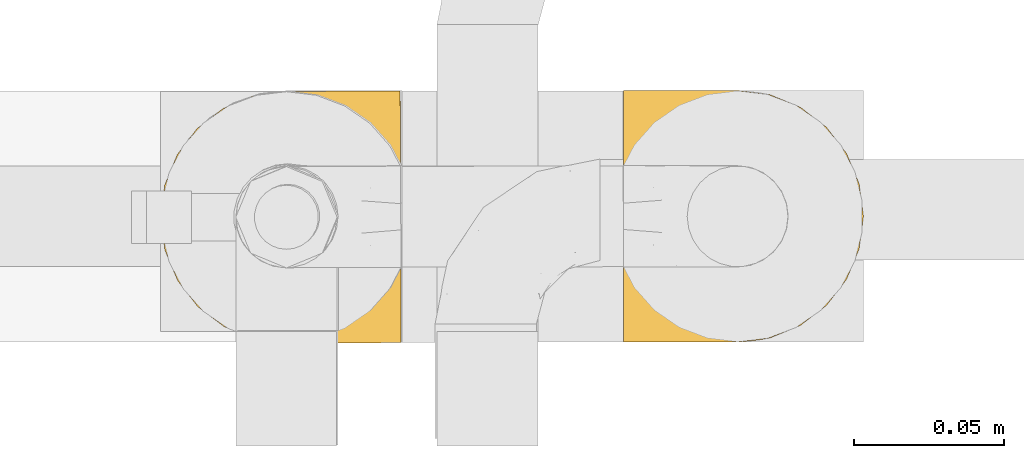
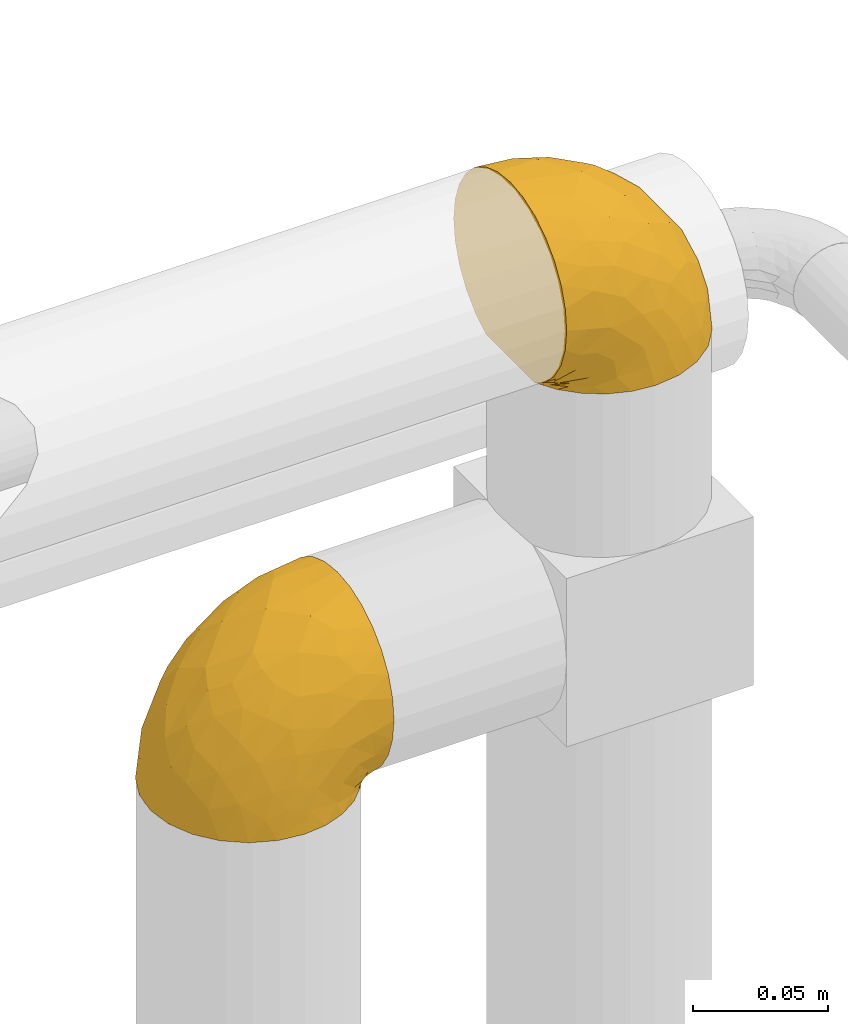
# One storey, part 359 of 827: 2 coverings.
"""IFC2X3 building model written with IfcOpenShell, lengths in millimetres."""

import ifcopenshell
import ifcopenshell.guid

model = None  # the IFC model being written
_history = None  # IfcOwnerHistory: only IFC2X3 demands one
_inside = {}  # id of a spatial element -> (the spatial element, [elements in it])
_under = {}  # id of a project, library or spatial element -> (it, [spatial elements below it])
_declared = {}  # id of a project -> (the project, [libraries it declares])
_typed = {}  # id of a type object -> (the type object, [elements of that type])
_made_of = {}  # id of a material, layer set ... -> (it, [elements and type objects made of it])


def new_model(schema):
    """Start an empty IFC model of exactly this schema.

    Asked for "IFC4X3", IfcOpenShell would pick the latest addendum, in which some entities
    have other attributes; the version numbers below select the first issue.
    IFC2X3 requires an IfcOwnerHistory on every rooted entity: one is made here for all.
    """
    global model, _history
    if schema == "IFC4X3":
        model = ifcopenshell.file(schema_version=(4, 3, 0, 0))
    else:
        model = ifcopenshell.file(schema=schema)
    _inside.clear()
    _under.clear()
    _declared.clear()
    _typed.clear()
    _made_of.clear()
    _history = None
    if model.schema == "IFC2X3":
        org = make("IfcOrganization", Name="unknown")
        user = make(
            "IfcPersonAndOrganization",
            ThePerson=make("IfcPerson", FamilyName="unknown"),
            TheOrganization=org,
        )
        app = make(
            "IfcApplication",
            ApplicationDeveloper=org,
            Version="unknown",
            ApplicationFullName="unknown",
            ApplicationIdentifier="unknown",
        )
        _history = make(
            "IfcOwnerHistory",
            OwningUser=user,
            OwningApplication=app,
            ChangeAction="ADDED",
            CreationDate=0,
        )
    return model


def make(cls, **values):
    """One entity of the class cls with the attributes given. An attribute that is None is left unset."""
    return model.create_entity(
        cls, **{name: value for name, value in values.items() if value is not None}
    )


def entity(cls, *values):
    """Any entity or typed value of the class cls, its attributes in the order of the schema. None: left unset."""
    e = model.create_entity(cls)
    for i, value in enumerate(values):
        if value is not None:
            e[i] = value
    return e


def rooted(cls, **values):
    """An entity with a GlobalId (a new one), such as an element, a storey or a relation."""
    return make(cls, GlobalId=ifcopenshell.guid.new(), OwnerHistory=_history, **values)


def si_unit(unit_type, name, prefix=None):
    """IfcSIUnit, for example si_unit("LENGTHUNIT", "METRE", prefix="MILLI")."""
    return make("IfcSIUnit", UnitType=unit_type, Prefix=prefix, Name=name)


def converted_unit(unit_type, name, factor, base, dimensions=None, offset=None):
    """IfcConversionBasedUnit, such as the inch: factor (a typed value) times the base unit."""
    return make(
        "IfcConversionBasedUnit"
        if offset is None
        else "IfcConversionBasedUnitWithOffset",
        ConversionOffset=offset,
        Dimensions=None
        if dimensions is None
        else entity("IfcDimensionalExponents", *dimensions),
        UnitType=unit_type,
        Name=name,
        ConversionFactor=make(
            "IfcMeasureWithUnit", ValueComponent=factor, UnitComponent=base
        ),
    )


def derived_unit(unit_type, elements):
    """IfcDerivedUnit: a product of units, each with its exponent."""
    return make(
        "IfcDerivedUnit",
        Elements=[
            make("IfcDerivedUnitElement", Unit=unit, Exponent=power)
            for unit, power in elements
        ],
        UnitType=unit_type,
    )


def assignment(units):
    """IfcUnitAssignment: the units of a project."""
    return None if units is None else make("IfcUnitAssignment", Units=units)


def point(xyz):
    """IfcCartesianPoint."""
    return None if xyz is None else make("IfcCartesianPoint", Coordinates=xyz)


def direction(xyz):
    """IfcDirection."""
    return None if xyz is None else make("IfcDirection", DirectionRatios=xyz)


def frame(location, z_axis=None, x_axis=None):
    """IfcAxis2Placement3D, a coordinate frame: its origin and axes. An axis left out is left unset."""
    return make(
        "IfcAxis2Placement3D",
        Location=point(location),
        Axis=direction(z_axis),
        RefDirection=direction(x_axis),
    )


def origin():
    """The frame at (0, 0, 0) with its axes left unset."""
    return frame((0.0, 0.0, 0.0))


def place(relative_to, where):
    """IfcLocalPlacement: puts the frame where relative to a parent placement (None: the world)."""
    return make(
        "IfcLocalPlacement", PlacementRelTo=relative_to, RelativePlacement=where
    )


def context(
    kind, dimensions, precision=None, world=None, true_north=None, identifier=None
):
    """IfcGeometricRepresentationContext, for example the 3D "Model" context."""
    return make(
        "IfcGeometricRepresentationContext",
        ContextIdentifier=identifier,
        ContextType=kind,
        CoordinateSpaceDimension=dimensions,
        Precision=precision,
        WorldCoordinateSystem=world,
        TrueNorth=true_north,
    )


def subcontext(parent, identifier, kind, view, scale=None):
    """IfcGeometricRepresentationSubContext, for example "Body" below "Model"."""
    return make(
        "IfcGeometricRepresentationSubContext",
        ContextIdentifier=identifier,
        ContextType=kind,
        ParentContext=parent,
        TargetScale=scale,
        TargetView=view,
    )


def project(units=None, contexts=None):
    """IfcProject with its units and contexts."""
    return rooted(
        "IfcProject",
        Name="project",
        RepresentationContexts=contexts,
        UnitsInContext=assignment(units),
    )


def spatial(cls, under=None, at=None, **own):
    """A site, building, storey or space (cls), placed at a placement, below another one or the project."""
    s = rooted(cls, ObjectPlacement=at, **own)
    if under is not None:
        _under.setdefault(under.id(), (under, []))[1].append(s)
    return s


def faces_of(points, faces, orient=None, outer=None):
    """IfcFace entities. A face is a list of loops; a loop is a list of indices into points, from 0.

    orient and outer hold one flag for each loop. By default every Orientation is true, the
    first loop of a face is its IfcFaceOuterBound and the others are IfcFaceBound.
    """
    made = []
    for i, loops in enumerate(faces):
        bounds = []
        for j, loop in enumerate(loops):
            is_outer = j == 0 if outer is None else outer[i][j]
            bounds.append(
                make(
                    "IfcFaceOuterBound" if is_outer else "IfcFaceBound",
                    Bound=make("IfcPolyLoop", Polygon=[points[k] for k in loop]),
                    Orientation=True if orient is None else orient[i][j],
                )
            )
        made.append(make("IfcFace", Bounds=bounds))
    return made


def faceted_brep(points, faces, orient=None, outer=None, voids=None):
    """IfcFacetedBrep: a solid bounded by flat faces; with voids (closed shells), ...WithVoids."""
    shared = [point(p) for p in points]
    hull = make("IfcClosedShell", CfsFaces=faces_of(shared, faces, orient, outer))
    if voids is None:
        return make("IfcFacetedBrep", Outer=hull)
    return make(
        "IfcFacetedBrepWithVoids",
        Outer=hull,
        Voids=[
            make(cls, CfsFaces=faces_of(shared, fs, o, b)) for cls, fs, o, b in voids
        ],
    )


def shape(context_of_items, identifier, shape_type, items):
    """IfcShapeRepresentation: the items that make up one representation, for example the "Body"."""
    return make(
        "IfcShapeRepresentation",
        ContextOfItems=context_of_items,
        RepresentationIdentifier=identifier,
        RepresentationType=shape_type,
        Items=items,
    )


def made_of(thing, what):
    """Note that an element or type object is made of a material, layer set ...; save() writes the relation."""
    if what is not None:
        _made_of.setdefault(what.id(), (what, []))[1].append(thing)
    return thing


def element(
    cls,
    number,
    at=None,
    inside=None,
    cuts=None,
    type_object=None,
    material=None,
    context=None,
    identifier="Body",
    shape_type=None,
    held_by="IfcProductDefinitionShape",
    body=None,
    shapes=None,
    **own,
):
    """One element of the class cls, such as IfcWall. Its Tag is "e" and its number.

    at: its placement. inside: the storey or other place that contains it. cuts: it is an
    opening in that element (IfcRelVoidsElement). A single representation is given by context,
    identifier, shape_type and body (its items); several are given by shapes. held_by: the class
    of the entity that holds the representations. save() writes the other relations.
    """
    e = rooted(cls, Tag="e%d" % number, ObjectPlacement=at, **own)
    if body is not None:
        shapes = [shape(context, identifier, shape_type, body)]
    if shapes is not None:
        e.Representation = make(held_by, Representations=shapes)
    if inside is not None:
        _inside.setdefault(inside.id(), (inside, []))[1].append(e)
    if cuts is not None:
        rooted(
            "IfcRelVoidsElement", RelatingBuildingElement=cuts, RelatedOpeningElement=e
        )
    if type_object is not None:
        _typed.setdefault(type_object.id(), (type_object, []))[1].append(e)
    return made_of(e, material)


def aggregate(whole, parts):
    """IfcRelAggregates: a whole, such as a stair, and the parts it consists of."""
    return rooted("IfcRelAggregates", RelatingObject=whole, RelatedObjects=parts)


def save(model, path):
    """Write the relations noted so far, then the file.

    IfcRelAggregates (storeys below a building ...), IfcRelContainedInSpatialStructure (elements
    in a storey), IfcRelDefinesByType, IfcRelAssociatesMaterial and IfcRelDeclares: one each for
    every whole, place, type object, material and project.
    """
    for whole, parts in _under.values():
        aggregate(whole, parts)
    for where, things in _inside.values():
        rooted(
            "IfcRelContainedInSpatialStructure",
            RelatedElements=things,
            RelatingStructure=where,
        )
    for kind, things in _typed.values():
        rooted("IfcRelDefinesByType", RelatedObjects=things, RelatingType=kind)
    for what, things in _made_of.values():
        rooted("IfcRelAssociatesMaterial", RelatedObjects=things, RelatingMaterial=what)
    for by, libraries in _declared.values():
        rooted("IfcRelDeclares", RelatingContext=by, RelatedDefinitions=libraries)
    model.write(path)


model = new_model("IFC2X3")

# Units and contexts
model_context = context("Model", 3, precision=0.01, world=origin(), true_north=direction((6.12303176911189e-17, 1.0)))
body_context = subcontext(model_context, "Body", "Model", "MODEL_VIEW")
ifc_project = project(units=[si_unit("LENGTHUNIT", "METRE", prefix="MILLI"), si_unit("AREAUNIT", "SQUARE_METRE"), si_unit("VOLUMEUNIT", "CUBIC_METRE"), converted_unit("PLANEANGLEUNIT", "DEGREE", entity("IfcRatioMeasure", 0.0174532925199433), si_unit("PLANEANGLEUNIT", "RADIAN"), dimensions=[0, 0, 0, 0, 0, 0, 0]), si_unit("MASSUNIT", "GRAM", prefix="KILO"), derived_unit("MASSDENSITYUNIT", [(si_unit("MASSUNIT", "GRAM", prefix="KILO"), 1), (si_unit("LENGTHUNIT", "METRE"), -3)]), derived_unit("MOMENTOFINERTIAUNIT", [(si_unit("LENGTHUNIT", "METRE"), 4)]), si_unit("TIMEUNIT", "SECOND"), si_unit("FREQUENCYUNIT", "HERTZ"), si_unit("THERMODYNAMICTEMPERATUREUNIT", "DEGREE_CELSIUS"), derived_unit("THERMALTRANSMITTANCEUNIT", [(si_unit("MASSUNIT", "GRAM", prefix="KILO"), 1), (si_unit("THERMODYNAMICTEMPERATUREUNIT", "KELVIN"), -1), (si_unit("TIMEUNIT", "SECOND"), -3)]), derived_unit("VOLUMETRICFLOWRATEUNIT", [(si_unit("LENGTHUNIT", "METRE"), 3), (si_unit("TIMEUNIT", "SECOND"), -1)]), derived_unit("MASSFLOWRATEUNIT", [(si_unit("MASSUNIT", "GRAM", prefix="KILO"), 1), (si_unit("TIMEUNIT", "SECOND"), -1)]), derived_unit("ROTATIONALFREQUENCYUNIT", [(si_unit("TIMEUNIT", "SECOND"), -1)]), si_unit("ELECTRICCURRENTUNIT", "AMPERE"), si_unit("ELECTRICVOLTAGEUNIT", "VOLT"), si_unit("POWERUNIT", "WATT"), si_unit("FORCEUNIT", "NEWTON", prefix="KILO"), si_unit("ILLUMINANCEUNIT", "LUX"), si_unit("LUMINOUSFLUXUNIT", "LUMEN"), si_unit("LUMINOUSINTENSITYUNIT", "CANDELA"), derived_unit("USERDEFINED", [(si_unit("MASSUNIT", "GRAM", prefix="KILO"), -1), (si_unit("LENGTHUNIT", "METRE"), -2), (si_unit("TIMEUNIT", "SECOND"), 3), (si_unit("LUMINOUSFLUXUNIT", "LUMEN"), 1)]), derived_unit("LINEARVELOCITYUNIT", [(si_unit("LENGTHUNIT", "METRE"), 1), (si_unit("TIMEUNIT", "SECOND"), -1)]), si_unit("PRESSUREUNIT", "PASCAL"), derived_unit("USERDEFINED", [(si_unit("LENGTHUNIT", "METRE"), -2), (si_unit("MASSUNIT", "GRAM", prefix="KILO"), 1), (si_unit("TIMEUNIT", "SECOND"), -2)]), derived_unit("LINEARFORCEUNIT", [(si_unit("MASSUNIT", "GRAM", prefix="KILO"), 1), (si_unit("LENGTHUNIT", "METRE"), 1), (si_unit("TIMEUNIT", "SECOND"), -2), (si_unit("LENGTHUNIT", "METRE"), -1)]), derived_unit("PLANARFORCEUNIT", [(si_unit("MASSUNIT", "GRAM", prefix="KILO"), 1), (si_unit("LENGTHUNIT", "METRE"), 1), (si_unit("TIMEUNIT", "SECOND"), -2), (si_unit("LENGTHUNIT", "METRE"), -2)])], contexts=[model_context])

# Site, building, storey
site_placement = place(None, origin())
site = spatial("IfcSite", under=ifc_project, at=site_placement, CompositionType="ELEMENT")
building_placement = place(site_placement, origin())
building = spatial("IfcBuilding", under=site, at=building_placement, CompositionType="ELEMENT")
storey_placement = place(building_placement, frame((0.0, 0.0, 28200.0)))
storey = spatial("IfcBuildingStorey", under=building, at=storey_placement, Name="08", CompositionType="ELEMENT", Elevation=28200.0)

# Coverings
covering_1_placement = place(storey_placement, frame((43109.64, 18027.49, 2810.4)))
element("IfcCovering", 1, at=covering_1_placement, inside=storey, Name=":ADSK_", ObjectType=":ADSK_", PredefinedType="INSULATION", context=body_context, shape_type="Brep", body=[
    faceted_brep([(81.34, 69.68, 72.32), (81.37, 61.75, 77.3), (81.41, 52.91, 80.4), (81.44, 43.6, 81.45), (81.48, 34.28, 80.39), (81.52, 25.43, 77.3), (81.55, 17.5, 72.31), (81.58, 10.87, 65.68), (81.6, 5.89, 57.75), (81.61, 2.8, 48.9), (81.61, 1.75, 39.6), (81.61, 2.81, 30.22), (81.6, 5.94, 21.33), (81.58, 10.99, 13.37), (81.55, 17.69, 6.73), (81.52, 25.69, 1.77), (81.51, 26.6, 1.77), (81.51, 27.52, 1.77), (81.51, 28.33, 1.77), (81.5, 29.65, 1.77), (81.5, 30.97, 1.77), (81.49, 32.29, 1.77), (81.48, 33.61, 1.77), (81.48, 34.93, 1.77), (81.47, 36.25, 1.77), (81.47, 37.57, 1.77), (81.46, 38.89, 1.77), (81.46, 40.21, 1.77), (81.45, 41.53, 1.77), (81.45, 42.85, 1.77), (81.44, 44.17, 1.77), (81.44, 45.49, 1.77), (81.43, 46.81, 1.77), (81.43, 47.73, 1.77), (81.42, 48.65, 1.77), (81.42, 49.57, 1.77), (81.42, 50.49, 1.77), (81.41, 51.4, 1.77), (81.41, 52.32, 1.77), (81.41, 53.24, 1.77), (81.4, 54.16, 1.77), (81.4, 55.08, 1.77), (81.39, 56.0, 1.77), (81.39, 56.92, 1.77), (81.39, 57.84, 1.77), (81.38, 58.75, 1.77), (81.38, 59.67, 1.77), (81.38, 60.59, 1.77), (81.37, 61.51, 1.77), (81.34, 69.52, 6.74), (81.31, 76.22, 13.38), (81.29, 81.26, 21.35), (81.28, 84.39, 30.24), (81.28, 85.45, 39.6), (81.28, 84.4, 48.91), (81.29, 81.3, 57.76), (81.31, 76.31, 65.69), (76.4, 17.66, 1.6), (69.8, 10.93, 1.6), (61.85, 5.86, 1.6), (52.97, 2.69, 1.6), (43.61, 1.6, 1.6), (32.78, 2.98, 1.6), (22.67, 7.12, 1.6), (13.97, 13.73, 1.6), (7.29, 22.37, 1.6), (3.06, 32.45, 1.6), (1.6, 43.28, 1.6), (2.98, 54.11, 1.6), (7.12, 64.22, 1.6), (13.73, 72.92, 1.6), (22.37, 79.6, 1.6), (32.45, 83.82, 1.6), (43.28, 85.29, 1.6), (52.65, 84.27, 1.6), (61.55, 81.18, 1.6), (69.53, 76.17, 1.6), (76.19, 69.5, 1.6), (81.2, 61.51, 1.6), (81.2, 60.59, 1.6), (81.2, 59.27, 1.6), (81.21, 58.15, 1.6), (81.21, 57.03, 1.6), (81.22, 55.91, 1.6), (81.22, 54.79, 1.6), (81.23, 53.67, 1.6), (81.23, 52.55, 1.6), (81.24, 51.43, 1.6), (81.24, 50.31, 1.6), (81.24, 49.2, 1.6), (81.25, 48.08, 1.6), (81.25, 46.96, 1.6), (81.26, 45.84, 1.6), (81.26, 44.72, 1.6), (81.27, 43.6, 1.6), (81.27, 42.28, 1.6), (81.28, 40.96, 1.6), (81.28, 39.64, 1.6), (81.29, 38.32, 1.6), (81.29, 37.0, 1.6), (81.3, 35.68, 1.6), (81.3, 34.36, 1.6), (81.31, 33.03, 1.6), (81.31, 32.12, 1.6), (81.32, 31.2, 1.6), (81.32, 30.28, 1.6), (81.32, 29.36, 1.6), (81.33, 28.44, 1.6), (81.33, 27.52, 1.6), (81.34, 26.6, 1.6), (81.34, 25.69, 1.6), (81.27, 54.23, 1.71), (81.28, 55.31, 1.73), (81.34, 36.34, 1.71), (81.35, 35.28, 1.72), (81.31, 44.16, 1.71), (81.31, 45.23, 1.72), (81.25, 61.51, 1.72), (81.25, 60.13, 1.72), (81.31, 46.33, 1.72), (81.39, 26.89, 1.72), (81.31, 47.51, 1.72), (81.37, 29.82, 1.72), (81.36, 28.87, 1.7), (81.33, 39.93, 1.72), (81.29, 53.11, 1.73), (81.28, 51.99, 1.72), (81.34, 40.95, 1.73), (81.33, 42.03, 1.73), (81.32, 43.09, 1.72), (81.38, 27.92, 1.72), (81.29, 48.55, 1.71), (81.34, 37.37, 1.72), (81.35, 33.7, 1.71), (81.36, 32.64, 1.72), (81.37, 30.84, 1.72), (81.29, 50.84, 1.72), (81.3, 49.76, 1.73), (81.27, 56.47, 1.72), (81.26, 57.59, 1.71), (81.27, 59.03, 1.73), (81.39, 25.69, 1.72), (81.29, 61.51, 1.74), (81.43, 25.69, 1.74), (81.22, 61.51, 1.64), (81.38, 25.69, 1.68), (81.36, 25.69, 1.64), (81.23, 61.51, 1.68), (81.47, 25.69, 1.75), (81.32, 61.51, 1.75), (81.39, 31.74, 1.74), (81.33, 38.86, 1.71), (58.66, 4.03, 8.98), (72.11, 1.71, 37.05), (74.73, 4.1, 24.69), (74.07, 8.21, 15.28), (78.32, 8.23, 16.86), (78.15, 16.57, 6.58), (76.34, 15.87, 5.71), (46.16, 1.61, 11.1), (74.14, 10.92, 10.79), (73.69, 14.11, 4.13), (66.8, 8.18, 6.62), (79.21, 14.14, 9.52), (73.26, 12.95, 6.14), (60.51, 3.25, 17.79), (48.7, 1.62, 20.6), (45.53, 1.6, 8.73), (67.38, 3.37, 23.66), (62.61, 1.67, 34.5), (68.82, 6.38, 15.32), (55.66, 1.64, 27.55), (77.94, 19.2, 3.31), (68.3, 8.18, 9.81), (74.48, 1.72, 37.68), (38.82, 32.09, 67.23), (62.16, 29.69, 76.64), (50.89, 43.47, 75.37), (37.07, 2.42, 14.58), (40.53, 2.49, 23.71), (28.0, 9.67, 34.34), (15.87, 17.86, 29.1), (20.27, 10.15, 18.02), (31.7, 4.73, 22.27), (28.41, 4.72, 10.97), (57.4, 8.06, 56.79), (70.13, 8.11, 60.76), (64.7, 13.93, 67.04), (50.81, 2.45, 36.11), (52.06, 21.21, 68.85), (5.76, 35.58, 24.58), (7.48, 27.28, 21.54), (66.14, 43.54, 78.4), (11.46, 17.84, 14.11), (21.68, 35.62, 53.42), (28.63, 29.41, 58.19), (55.54, 3.46, 44.49), (68.67, 4.04, 51.77), (67.57, 21.27, 73.69), (40.92, 7.91, 45.89), (41.68, 4.25, 35.97), (46.23, 11.77, 56.55), (40.42, 18.3, 60.03), (38.44, 24.92, 63.64), (11.9, 28.66, 34.98), (12.59, 35.7, 40.58), (7.67, 43.3, 32.15), (19.45, 28.28, 47.26), (24.98, 43.37, 58.06), (37.94, 43.42, 66.71), (4.64, 43.29, 16.9), (28.18, 21.15, 52.08), (23.84, 16.4, 41.21), (34.15, 13.81, 49.76), (16.33, 43.34, 45.11), (29.13, 82.05, 15.65), (5.74, 51.26, 24.57), (21.38, 57.36, 50.54), (38.75, 54.76, 67.25), (64.46, 73.12, 67.06), (67.4, 65.8, 73.7), (22.77, 76.56, 26.13), (12.44, 68.8, 19.54), (19.94, 67.92, 38.96), (57.12, 78.93, 56.8), (69.85, 78.98, 60.77), (68.35, 83.05, 51.78), (34.45, 64.41, 59.09), (38.65, 84.48, 19.25), (48.37, 85.32, 20.6), (45.82, 85.3, 11.1), (74.14, 85.42, 37.68), (5.3, 57.68, 15.21), (18.82, 76.55, 12.76), (12.76, 51.06, 40.93), (62.05, 57.34, 76.65), (33.0, 78.1, 39.5), (33.28, 82.31, 25.01), (51.89, 65.74, 68.86), (43.25, 84.61, 26.7), (48.45, 84.38, 34.95), (62.28, 85.37, 34.5), (55.32, 85.34, 27.55), (49.56, 73.06, 61.27), (55.2, 83.52, 44.5), (71.78, 85.41, 37.05), (36.21, 84.51, 10.25), (33.92, 72.99, 49.78), (43.95, 79.54, 47.51), (9.93, 59.33, 29.38), (26.29, 73.43, 40.01), (39.04, 82.55, 33.36), (58.34, 82.98, 8.98), (67.05, 83.71, 23.67), (74.41, 83.05, 24.71), (73.78, 78.94, 15.29), (73.45, 73.02, 4.13), (73.01, 74.18, 6.14), (66.05, 78.9, 4.96), (68.02, 78.91, 9.81), (77.74, 67.97, 3.31), (76.12, 71.29, 5.7), (78.96, 73.05, 9.53), (77.93, 70.61, 6.59), (77.04, 78.95, 16.63), (68.51, 80.72, 15.34), (73.87, 76.23, 10.8), (60.18, 83.78, 17.79)], [[[0, 1, 2, 3, 4, 5, 6, 7, 8, 9, 10, 11, 12, 13, 14, 15, 16, 17, 18, 19, 20, 21, 22, 23, 24, 25, 26, 27, 28, 29, 30, 31, 32, 33, 34, 35, 36, 37, 38, 39, 40, 41, 42, 43, 44, 45, 46, 47, 48, 49, 50, 51, 52, 53, 54, 55, 56]], [[57, 58, 59, 60, 61, 62, 63, 64, 65, 66, 67, 68, 69, 70, 71, 72, 73, 74, 75, 76, 77, 78, 79, 80, 81, 82, 83, 84, 85, 86, 87, 88, 89, 90, 91, 92, 93, 94, 95, 96, 97, 98, 99, 100, 101, 102, 103, 104, 105, 106, 107, 108, 109, 110]], [[111, 84, 112]], [[113, 24, 114]], [[114, 101, 100]], [[115, 93, 116]], [[79, 117, 118]], [[31, 116, 119]], [[117, 47, 118]], [[17, 16, 120]], [[119, 121, 32]], [[122, 19, 123]], [[97, 96, 124]], [[86, 125, 126]], [[116, 92, 119]], [[127, 96, 128]], [[30, 129, 115]], [[17, 120, 130]], [[121, 90, 131]], [[94, 115, 129]], [[115, 116, 30]], [[118, 47, 46]], [[113, 99, 132]], [[133, 114, 23]], [[22, 134, 133]], [[135, 20, 122]], [[136, 137, 88]], [[84, 83, 112]], [[138, 82, 139]], [[130, 18, 17]], [[118, 46, 140]], [[81, 140, 139]], [[123, 19, 18]], [[141, 120, 16]], [[139, 82, 81]], [[130, 107, 123]], [[47, 117, 142]], [[16, 143, 141]], [[79, 78, 144]], [[109, 145, 146, 110]], [[102, 133, 134]], [[105, 135, 122]], [[109, 141, 145]], [[79, 144, 147, 117]], [[118, 80, 79]], [[80, 118, 140]], [[16, 15, 148]], [[47, 149, 48]], [[120, 109, 108]], [[45, 44, 140, 46]], [[81, 80, 140]], [[42, 112, 138]], [[93, 115, 94]], [[44, 139, 140]], [[44, 43, 139]], [[139, 43, 138]], [[138, 112, 83]], [[85, 84, 111]], [[112, 41, 111]], [[83, 82, 138]], [[106, 122, 123]], [[105, 122, 106]], [[19, 122, 20]], [[124, 27, 26]], [[31, 30, 116]], [[128, 129, 29]], [[30, 29, 129]], [[32, 31, 119]], [[116, 93, 92]], [[129, 95, 94]], [[95, 129, 128]], [[39, 38, 125, 40]], [[119, 91, 121]], [[34, 33, 131, 35]], [[137, 131, 89]], [[121, 131, 33]], [[90, 121, 91]], [[119, 92, 91]], [[136, 126, 37]], [[125, 86, 85]], [[40, 125, 111]], [[85, 111, 125]], [[150, 21, 20]], [[130, 108, 107]], [[130, 123, 18]], [[107, 106, 123]], [[137, 35, 131]], [[136, 36, 137]], [[89, 88, 137]], [[131, 90, 89]], [[124, 151, 97]], [[38, 37, 126]], [[87, 126, 136]], [[86, 126, 87]], [[136, 88, 87]], [[38, 126, 125]], [[37, 36, 136]], [[95, 128, 96]], [[28, 128, 29]], [[27, 124, 127]], [[127, 128, 28]], [[151, 124, 26]], [[127, 28, 27]], [[127, 124, 96]], [[151, 98, 97]], [[43, 42, 138]], [[24, 113, 132]], [[113, 100, 99]], [[132, 151, 25]], [[25, 24, 132]], [[24, 23, 114]], [[100, 113, 114]], [[101, 133, 102]], [[133, 101, 114]], [[26, 25, 151]], [[132, 99, 98]], [[21, 134, 22]], [[23, 22, 133]], [[134, 21, 150]], [[135, 104, 150]], [[150, 104, 103]], [[103, 102, 134]], [[130, 120, 108]], [[109, 120, 141]], [[40, 111, 41]], [[112, 42, 41]], [[104, 135, 105]], [[134, 150, 103]], [[135, 150, 20]], [[33, 32, 121]], [[137, 36, 35]], [[98, 151, 132]], [[59, 152, 60]], [[11, 153, 154]], [[155, 156, 154]], [[157, 158, 141]], [[159, 60, 152]], [[160, 157, 155]], [[161, 162, 58]], [[58, 162, 59]], [[148, 14, 163]], [[58, 57, 161]], [[162, 161, 164]], [[157, 163, 155]], [[163, 14, 13]], [[57, 146, 161]], [[152, 165, 166]], [[157, 148, 163]], [[60, 159, 167, 61]], [[156, 12, 154]], [[163, 156, 155]], [[155, 154, 168]], [[168, 154, 169]], [[155, 170, 160]], [[57, 110, 146]], [[148, 15, 14]], [[156, 13, 12]], [[171, 165, 168]], [[158, 164, 172]], [[12, 11, 154]], [[157, 141, 143, 148]], [[173, 164, 158]], [[173, 160, 170]], [[171, 166, 165]], [[168, 165, 170]], [[168, 169, 171]], [[152, 173, 165]], [[170, 155, 168]], [[165, 173, 170]], [[160, 173, 158]], [[172, 146, 145]], [[145, 141, 158]], [[158, 157, 160]], [[152, 166, 159]], [[173, 152, 162]], [[59, 162, 152]], [[11, 10, 174, 153]], [[153, 169, 154]], [[13, 156, 163]], [[162, 164, 173]], [[172, 164, 161]], [[146, 172, 161]], [[158, 172, 145]], [[175, 176, 177]], [[178, 166, 179]], [[180, 181, 182]], [[183, 184, 178]], [[185, 186, 187]], [[171, 188, 179]], [[174, 10, 9]], [[189, 176, 175]], [[190, 66, 191]], [[176, 4, 192]], [[193, 65, 64]], [[63, 184, 182]], [[63, 182, 64]], [[65, 193, 191]], [[184, 63, 62]], [[175, 194, 195]], [[196, 169, 197]], [[174, 9, 197]], [[6, 5, 198]], [[187, 7, 6]], [[197, 169, 153, 174]], [[197, 9, 8]], [[186, 197, 8]], [[199, 180, 200]], [[197, 185, 196]], [[201, 189, 202]], [[201, 187, 189]], [[195, 203, 175]], [[191, 204, 190]], [[176, 5, 4]], [[177, 176, 192]], [[189, 198, 176]], [[65, 191, 66]], [[198, 187, 6]], [[205, 206, 190]], [[7, 186, 8]], [[181, 207, 204]], [[208, 175, 177, 209]], [[66, 190, 210]], [[211, 212, 213]], [[190, 204, 205]], [[180, 182, 183]], [[193, 182, 181]], [[62, 61, 167]], [[196, 185, 199]], [[196, 200, 188]], [[4, 3, 192]], [[176, 198, 5]], [[187, 198, 189]], [[187, 186, 7]], [[197, 186, 185]], [[200, 180, 183]], [[180, 213, 212]], [[179, 183, 178]], [[185, 201, 199]], [[210, 190, 206]], [[210, 67, 66]], [[205, 204, 207]], [[194, 205, 207]], [[194, 214, 205]], [[195, 194, 207]], [[208, 194, 175]], [[207, 211, 195]], [[202, 203, 211]], [[212, 207, 181]], [[202, 211, 213]], [[201, 202, 213]], [[189, 175, 203]], [[199, 201, 213]], [[187, 201, 185]], [[180, 199, 213]], [[196, 199, 200]], [[211, 203, 195]], [[189, 203, 202]], [[207, 212, 211]], [[180, 212, 181]], [[214, 194, 208]], [[214, 206, 205]], [[196, 188, 169]], [[181, 204, 191]], [[182, 193, 64]], [[191, 193, 181]], [[178, 62, 167]], [[182, 184, 183]], [[62, 178, 184]], [[178, 167, 159, 166]], [[171, 179, 166]], [[200, 183, 179]], [[179, 188, 200]], [[169, 188, 171]], [[71, 215, 72]], [[206, 216, 210]], [[217, 208, 218]], [[216, 68, 210]], [[219, 220, 0]], [[221, 222, 223]], [[224, 225, 226]], [[227, 223, 217]], [[228, 229, 230]], [[54, 231, 226]], [[232, 222, 69]], [[54, 53, 231]], [[70, 233, 71]], [[71, 233, 215]], [[55, 54, 226]], [[208, 217, 234]], [[218, 177, 235]], [[221, 236, 237]], [[238, 220, 219]], [[56, 219, 0]], [[68, 216, 232]], [[235, 1, 220]], [[235, 192, 2]], [[56, 55, 225]], [[228, 239, 229]], [[240, 241, 242]], [[243, 238, 219]], [[224, 226, 244]], [[226, 241, 244]], [[1, 235, 2]], [[69, 222, 70]], [[225, 219, 56]], [[218, 235, 238]], [[243, 219, 224]], [[218, 227, 217]], [[1, 0, 220]], [[218, 208, 209, 177]], [[226, 231, 245, 241]], [[215, 228, 246]], [[247, 248, 236]], [[248, 224, 244]], [[223, 222, 249]], [[233, 222, 221]], [[242, 239, 240]], [[248, 247, 243]], [[217, 223, 249]], [[250, 247, 236]], [[216, 234, 249]], [[218, 238, 227]], [[192, 235, 177]], [[192, 3, 2]], [[72, 246, 73]], [[235, 220, 238]], [[226, 225, 55]], [[219, 225, 224]], [[240, 248, 244]], [[239, 242, 229]], [[236, 248, 251]], [[68, 67, 210]], [[234, 216, 206]], [[216, 249, 232]], [[234, 206, 214, 208]], [[249, 234, 217]], [[222, 232, 249]], [[69, 68, 232]], [[246, 228, 230]], [[237, 228, 215]], [[243, 227, 238]], [[223, 227, 247]], [[73, 246, 230]], [[215, 246, 72]], [[248, 243, 224]], [[227, 243, 247]], [[237, 236, 251]], [[250, 221, 223]], [[222, 233, 70]], [[215, 233, 221]], [[221, 237, 215]], [[239, 237, 251]], [[237, 239, 228]], [[239, 251, 240]], [[248, 240, 251]], [[241, 240, 244]], [[221, 250, 236]], [[223, 247, 250]], [[74, 230, 252]], [[253, 254, 255]], [[144, 77, 256]], [[257, 258, 259]], [[260, 256, 257]], [[260, 261, 147]], [[75, 74, 252]], [[49, 149, 262]], [[263, 149, 142]], [[256, 77, 76]], [[252, 258, 75]], [[253, 241, 254]], [[254, 245, 52]], [[258, 256, 76]], [[51, 50, 264]], [[255, 265, 253]], [[254, 264, 255]], [[255, 264, 262]], [[75, 258, 76]], [[265, 255, 266]], [[255, 262, 263]], [[49, 48, 149]], [[52, 245, 231, 53]], [[49, 262, 50]], [[253, 267, 242]], [[254, 52, 51]], [[266, 259, 265]], [[144, 78, 77]], [[263, 117, 261]], [[144, 256, 260]], [[257, 259, 261]], [[267, 253, 265]], [[229, 267, 252]], [[242, 267, 229]], [[242, 241, 253]], [[252, 267, 259]], [[255, 263, 266]], [[259, 267, 265]], [[261, 117, 147]], [[263, 261, 266]], [[259, 266, 261]], [[230, 74, 73]], [[230, 229, 252]], [[259, 258, 252]], [[254, 241, 245]], [[51, 264, 254]], [[50, 262, 264]], [[149, 263, 262]], [[142, 117, 263]], [[258, 257, 256]], [[261, 260, 257]], [[144, 260, 147]], [[47, 142, 149]], [[16, 148, 143]]]),
])
covering_2_placement = place(storey_placement, frame((43263.49, 18027.79, 2960.4)))
element("IfcCovering", 2, at=covering_2_placement, inside=storey, Name=":ADSK_", ObjectType=":ADSK_", PredefinedType="INSULATION", context=body_context, shape_type="Brep", body=[
    faceted_brep([(1.6, 5.74, 57.76), (1.6, 10.73, 65.69), (1.6, 17.36, 72.32), (1.6, 25.29, 77.3), (1.6, 34.14, 80.4), (1.6, 43.45, 81.45), (1.6, 52.76, 80.39), (1.6, 61.61, 77.3), (1.6, 69.54, 72.31), (1.6, 76.17, 65.68), (1.6, 81.15, 57.75), (1.6, 84.25, 48.9), (1.6, 85.3, 39.6), (1.6, 84.23, 30.22), (1.6, 81.1, 21.33), (1.6, 76.06, 13.37), (1.6, 69.36, 6.73), (1.6, 61.36, 1.77), (1.6, 60.44, 1.77), (1.6, 59.52, 1.77), (1.6, 58.72, 1.77), (1.6, 57.4, 1.77), (1.6, 56.08, 1.77), (1.6, 54.76, 1.77), (1.6, 53.44, 1.77), (1.6, 52.12, 1.77), (1.6, 50.8, 1.77), (1.6, 49.47, 1.77), (1.6, 48.15, 1.77), (1.6, 46.83, 1.77), (1.6, 45.51, 1.77), (1.6, 44.19, 1.77), (1.6, 42.87, 1.77), (1.6, 41.55, 1.77), (1.6, 40.23, 1.77), (1.6, 39.31, 1.77), (1.6, 38.39, 1.77), (1.6, 37.48, 1.77), (1.6, 36.56, 1.77), (1.6, 35.64, 1.77), (1.6, 34.72, 1.77), (1.6, 33.8, 1.77), (1.6, 32.88, 1.77), (1.6, 31.96, 1.77), (1.6, 31.05, 1.77), (1.6, 30.13, 1.77), (1.6, 29.21, 1.77), (1.6, 28.29, 1.77), (1.6, 27.37, 1.77), (1.6, 26.45, 1.77), (1.6, 25.53, 1.77), (1.6, 17.52, 6.74), (1.6, 10.82, 13.38), (1.6, 5.78, 21.35), (1.6, 2.65, 30.24), (1.6, 1.6, 39.6), (1.6, 2.65, 48.91), (6.74, 69.37, 1.6), (13.37, 76.06, 1.6), (21.34, 81.1, 1.6), (30.23, 84.23, 1.6), (39.6, 85.3, 1.6), (50.43, 83.87, 1.6), (60.52, 79.69, 1.6), (69.19, 73.04, 1.6), (75.84, 64.37, 1.6), (80.02, 54.28, 1.6), (81.45, 43.45, 1.6), (80.02, 32.61, 1.6), (75.84, 22.52, 1.6), (69.19, 13.85, 1.6), (60.52, 7.2, 1.6), (50.43, 3.02, 1.6), (39.6, 1.6, 1.6), (30.23, 2.66, 1.6), (21.34, 5.79, 1.6), (13.37, 10.83, 1.6), (6.74, 17.52, 1.6), (1.77, 25.53, 1.6), (1.77, 26.45, 1.6), (1.77, 27.77, 1.6), (1.77, 28.89, 1.6), (1.77, 30.01, 1.6), (1.77, 31.13, 1.6), (1.77, 32.25, 1.6), (1.77, 33.37, 1.6), (1.77, 34.49, 1.6), (1.77, 35.61, 1.6), (1.77, 36.73, 1.6), (1.77, 37.85, 1.6), (1.77, 38.97, 1.6), (1.77, 40.09, 1.6), (1.77, 41.21, 1.6), (1.77, 42.33, 1.6), (1.77, 43.45, 1.6), (1.77, 44.77, 1.6), (1.77, 46.09, 1.6), (1.77, 47.41, 1.6), (1.77, 48.73, 1.6), (1.77, 50.05, 1.6), (1.77, 51.37, 1.6), (1.77, 52.69, 1.6), (1.77, 54.01, 1.6), (1.77, 54.93, 1.6), (1.77, 55.85, 1.6), (1.77, 56.76, 1.6), (1.77, 57.68, 1.6), (1.77, 58.6, 1.6), (1.77, 59.52, 1.6), (1.77, 60.44, 1.6), (1.77, 61.36, 1.6), (1.73, 32.81, 1.71), (1.72, 31.73, 1.73), (1.73, 50.71, 1.71), (1.72, 51.76, 1.72), (1.73, 42.89, 1.71), (1.73, 41.81, 1.72), (1.72, 25.53, 1.72), (1.72, 26.91, 1.72), (1.72, 40.71, 1.72), (1.72, 60.15, 1.72), (1.72, 39.53, 1.72), (1.73, 57.22, 1.72), (1.74, 58.17, 1.7), (1.72, 47.12, 1.72), (1.71, 33.93, 1.73), (1.73, 35.05, 1.72), (1.71, 46.09, 1.73), (1.72, 45.02, 1.73), (1.73, 43.95, 1.72), (1.72, 59.12, 1.72), (1.73, 38.49, 1.71), (1.72, 49.68, 1.72), (1.73, 53.35, 1.71), (1.72, 54.4, 1.72), (1.72, 56.2, 1.72), (1.72, 36.2, 1.72), (1.71, 37.29, 1.73), (1.72, 30.57, 1.72), (1.73, 29.45, 1.71), (1.71, 28.01, 1.73), (1.72, 61.36, 1.72), (1.68, 25.53, 1.74), (1.64, 25.53, 1.75), (1.64, 61.36, 1.75), (1.68, 61.36, 1.74), (1.75, 25.53, 1.64), (1.74, 25.53, 1.68), (1.74, 61.36, 1.68), (1.75, 61.36, 1.64), (1.7, 55.3, 1.74), (1.73, 48.18, 1.71), (24.54, 82.92, 8.98), (11.1, 85.3, 37.05), (8.47, 82.92, 24.69), (9.11, 78.8, 15.28), (4.86, 78.8, 16.86), (5.0, 70.46, 6.58), (6.81, 71.16, 5.71), (37.05, 85.3, 11.1), (9.03, 76.1, 10.79), (9.47, 72.9, 4.13), (16.39, 78.81, 6.62), (3.95, 72.89, 9.52), (9.9, 74.06, 6.14), (22.7, 83.71, 17.79), (34.5, 85.3, 20.6), (37.68, 85.3, 8.73), (15.82, 83.61, 23.66), (20.6, 85.3, 34.5), (14.37, 80.61, 15.32), (27.55, 85.3, 27.55), (5.2, 67.83, 3.31), (14.88, 78.81, 9.81), (8.73, 85.3, 37.68), (44.27, 54.78, 67.23), (20.94, 57.27, 76.64), (32.15, 43.45, 75.37), (46.13, 84.45, 14.58), (42.67, 84.39, 23.71), (55.18, 77.16, 34.34), (67.27, 68.92, 29.1), (62.91, 76.65, 18.02), (51.5, 82.11, 22.27), (54.79, 82.11, 10.97), (25.78, 78.88, 56.79), (13.05, 78.88, 60.76), (18.46, 73.04, 67.04), (32.4, 84.47, 36.11), (31.07, 65.72, 68.85), (77.32, 51.16, 24.58), (75.62, 59.46, 21.54), (16.9, 43.45, 78.4), (71.69, 68.92, 14.11), (61.4, 51.18, 53.42), (54.47, 57.42, 58.19), (27.66, 83.48, 44.49), (14.53, 82.95, 51.77), (15.56, 65.72, 73.69), (42.26, 78.97, 45.89), (41.51, 82.64, 35.97), (36.93, 75.14, 56.55), (42.72, 68.58, 60.03), (44.68, 61.95, 63.64), (71.2, 58.11, 34.98), (70.48, 51.07, 40.58), (75.37, 43.45, 32.15), (63.65, 58.51, 47.26), (58.06, 43.45, 58.06), (45.11, 43.45, 66.71), (78.4, 43.45, 16.9), (54.95, 65.68, 52.08), (59.31, 70.41, 41.21), (49.01, 73.04, 49.76), (66.71, 43.45, 45.11), (53.75, 4.78, 15.65), (77.27, 35.48, 24.57), (61.6, 29.45, 50.54), (44.24, 32.11, 67.25), (18.46, 13.86, 67.06), (15.55, 21.19, 73.7), (60.14, 10.24, 26.13), (70.5, 17.97, 19.54), (63.0, 18.88, 38.96), (25.78, 8.01, 56.8), (13.05, 8.01, 60.77), (14.53, 3.95, 51.78), (48.5, 22.45, 59.09), (44.23, 2.4, 19.25), (34.5, 1.6, 20.6), (37.05, 1.6, 11.1), (8.73, 1.6, 37.68), (77.68, 29.05, 15.21), (64.08, 10.24, 12.76), (70.25, 35.7, 40.93), (20.93, 29.63, 76.65), (49.9, 8.75, 39.5), (49.6, 4.54, 25.01), (31.06, 21.19, 68.86), (39.62, 2.28, 26.7), (34.42, 2.53, 34.95), (20.6, 1.6, 34.5), (27.55, 1.6, 27.55), (33.36, 13.86, 61.27), (27.68, 3.41, 44.5), (11.1, 1.6, 37.05), (46.67, 2.35, 10.25), (49.0, 13.86, 49.78), (38.94, 7.35, 47.51), (73.05, 27.43, 29.38), (56.63, 13.39, 40.01), (43.85, 4.32, 33.36), (24.54, 3.97, 8.98), (15.82, 3.27, 23.67), (8.47, 3.97, 24.71), (9.12, 8.08, 15.29), (9.47, 13.99, 4.13), (9.91, 12.83, 6.14), (16.85, 8.08, 4.96), (14.88, 8.08, 9.81), (5.2, 19.06, 3.31), (6.81, 15.74, 5.7), (3.96, 13.98, 9.53), (5.0, 16.42, 6.59), (5.86, 8.08, 16.63), (14.38, 6.27, 15.34), (9.04, 10.78, 10.8), (22.7, 3.18, 17.79)], [[[0, 1, 2, 3, 4, 5, 6, 7, 8, 9, 10, 11, 12, 13, 14, 15, 16, 17, 18, 19, 20, 21, 22, 23, 24, 25, 26, 27, 28, 29, 30, 31, 32, 33, 34, 35, 36, 37, 38, 39, 40, 41, 42, 43, 44, 45, 46, 47, 48, 49, 50, 51, 52, 53, 54, 55, 56]], [[57, 58, 59, 60, 61, 62, 63, 64, 65, 66, 67, 68, 69, 70, 71, 72, 73, 74, 75, 76, 77, 78, 79, 80, 81, 82, 83, 84, 85, 86, 87, 88, 89, 90, 91, 92, 93, 94, 95, 96, 97, 98, 99, 100, 101, 102, 103, 104, 105, 106, 107, 108, 109, 110]], [[111, 84, 112]], [[113, 26, 114]], [[114, 101, 100]], [[115, 93, 116]], [[79, 117, 118]], [[33, 116, 119]], [[117, 49, 118]], [[19, 18, 120]], [[119, 121, 34]], [[122, 21, 123]], [[97, 96, 124]], [[86, 125, 126]], [[116, 92, 119]], [[127, 96, 128]], [[32, 129, 115]], [[19, 120, 130]], [[121, 90, 131]], [[94, 115, 129]], [[115, 116, 32]], [[118, 49, 48]], [[113, 99, 132]], [[133, 114, 25]], [[24, 134, 133]], [[135, 22, 122]], [[136, 137, 88]], [[84, 83, 112]], [[138, 82, 139]], [[130, 20, 19]], [[118, 48, 140]], [[81, 140, 139]], [[123, 21, 20]], [[141, 120, 18]], [[139, 82, 81]], [[130, 107, 123]], [[49, 117, 142, 143, 50]], [[18, 17, 144, 145, 141]], [[79, 78, 146, 147, 117]], [[109, 141, 148, 149, 110]], [[102, 133, 134]], [[105, 135, 122]], [[118, 80, 79]], [[80, 118, 140]], [[120, 109, 108]], [[47, 46, 140, 48]], [[81, 80, 140]], [[44, 112, 138]], [[93, 115, 94]], [[46, 139, 140]], [[46, 45, 139]], [[139, 45, 138]], [[138, 112, 83]], [[85, 84, 111]], [[112, 43, 111]], [[83, 82, 138]], [[106, 122, 123]], [[105, 122, 106]], [[21, 122, 22]], [[124, 29, 28]], [[33, 32, 116]], [[128, 129, 31]], [[32, 31, 129]], [[34, 33, 119]], [[116, 93, 92]], [[129, 95, 94]], [[95, 129, 128]], [[41, 40, 125, 42]], [[119, 91, 121]], [[36, 35, 131, 37]], [[137, 131, 89]], [[121, 131, 35]], [[90, 121, 91]], [[119, 92, 91]], [[136, 126, 39]], [[125, 86, 85]], [[42, 125, 111]], [[85, 111, 125]], [[150, 23, 22]], [[130, 108, 107]], [[130, 123, 20]], [[107, 106, 123]], [[137, 37, 131]], [[136, 38, 137]], [[89, 88, 137]], [[131, 90, 89]], [[124, 151, 97]], [[40, 39, 126]], [[87, 126, 136]], [[86, 126, 87]], [[136, 88, 87]], [[40, 126, 125]], [[39, 38, 136]], [[95, 128, 96]], [[30, 128, 31]], [[29, 124, 127]], [[127, 128, 30]], [[151, 124, 28]], [[127, 30, 29]], [[127, 124, 96]], [[151, 98, 97]], [[45, 44, 138]], [[26, 113, 132]], [[113, 100, 99]], [[132, 151, 27]], [[27, 26, 132]], [[26, 25, 114]], [[100, 113, 114]], [[101, 133, 102]], [[133, 101, 114]], [[28, 27, 151]], [[132, 99, 98]], [[23, 134, 24]], [[25, 24, 133]], [[134, 23, 150]], [[135, 104, 150]], [[150, 104, 103]], [[103, 102, 134]], [[130, 120, 108]], [[109, 120, 141]], [[42, 111, 43]], [[112, 44, 43]], [[104, 135, 105]], [[134, 150, 103]], [[135, 150, 22]], [[35, 34, 121]], [[137, 38, 37]], [[98, 151, 132]], [[59, 152, 60]], [[13, 153, 154]], [[155, 156, 154]], [[157, 158, 141]], [[159, 60, 152]], [[160, 157, 155]], [[161, 162, 58]], [[58, 162, 59]], [[144, 16, 163]], [[58, 57, 161]], [[162, 161, 164]], [[157, 163, 155]], [[163, 16, 15]], [[57, 149, 161]], [[152, 165, 166]], [[157, 144, 163]], [[60, 159, 167, 61]], [[156, 14, 154]], [[163, 156, 155]], [[155, 154, 168]], [[168, 154, 169]], [[155, 170, 160]], [[57, 110, 149]], [[144, 17, 16]], [[156, 15, 14]], [[171, 165, 168]], [[158, 164, 172]], [[14, 13, 154]], [[157, 141, 145, 144]], [[173, 164, 158]], [[173, 160, 170]], [[171, 166, 165]], [[168, 165, 170]], [[168, 169, 171]], [[152, 173, 165]], [[170, 155, 168]], [[165, 173, 170]], [[160, 173, 158]], [[172, 149, 148]], [[148, 141, 158]], [[158, 157, 160]], [[152, 166, 159]], [[173, 152, 162]], [[59, 162, 152]], [[13, 12, 174, 153]], [[153, 169, 154]], [[15, 156, 163]], [[162, 164, 173]], [[172, 164, 161]], [[149, 172, 161]], [[158, 172, 148]], [[175, 176, 177]], [[178, 166, 179]], [[180, 181, 182]], [[183, 184, 178]], [[185, 186, 187]], [[171, 188, 179]], [[174, 12, 11]], [[189, 176, 175]], [[190, 66, 191]], [[176, 6, 192]], [[193, 65, 64]], [[63, 184, 182]], [[63, 182, 64]], [[65, 193, 191]], [[184, 63, 62]], [[175, 194, 195]], [[196, 169, 197]], [[174, 11, 197]], [[8, 7, 198]], [[187, 9, 8]], [[197, 169, 153, 174]], [[197, 11, 10]], [[186, 197, 10]], [[199, 180, 200]], [[197, 185, 196]], [[201, 189, 202]], [[201, 187, 189]], [[195, 203, 175]], [[191, 204, 190]], [[176, 7, 6]], [[177, 176, 192]], [[189, 198, 176]], [[65, 191, 66]], [[198, 187, 8]], [[205, 206, 190]], [[9, 186, 10]], [[181, 207, 204]], [[208, 175, 177, 209]], [[66, 190, 210]], [[211, 212, 213]], [[190, 204, 205]], [[180, 182, 183]], [[193, 182, 181]], [[62, 61, 167]], [[196, 185, 199]], [[196, 200, 188]], [[6, 5, 192]], [[176, 198, 7]], [[187, 198, 189]], [[187, 186, 9]], [[197, 186, 185]], [[200, 180, 183]], [[180, 213, 212]], [[179, 183, 178]], [[185, 201, 199]], [[210, 190, 206]], [[210, 67, 66]], [[205, 204, 207]], [[194, 205, 207]], [[194, 214, 205]], [[195, 194, 207]], [[208, 194, 175]], [[207, 211, 195]], [[202, 203, 211]], [[212, 207, 181]], [[202, 211, 213]], [[201, 202, 213]], [[189, 175, 203]], [[199, 201, 213]], [[187, 201, 185]], [[180, 199, 213]], [[196, 199, 200]], [[211, 203, 195]], [[189, 203, 202]], [[207, 212, 211]], [[180, 212, 181]], [[214, 194, 208]], [[214, 206, 205]], [[196, 188, 169]], [[181, 204, 191]], [[182, 193, 64]], [[191, 193, 181]], [[178, 62, 167]], [[182, 184, 183]], [[62, 178, 184]], [[178, 167, 159, 166]], [[171, 179, 166]], [[200, 183, 179]], [[179, 188, 200]], [[169, 188, 171]], [[71, 215, 72]], [[206, 216, 210]], [[217, 208, 218]], [[216, 68, 210]], [[219, 220, 2]], [[221, 222, 223]], [[224, 225, 226]], [[227, 223, 217]], [[228, 229, 230]], [[56, 231, 226]], [[232, 222, 69]], [[56, 55, 231]], [[70, 233, 71]], [[71, 233, 215]], [[0, 56, 226]], [[208, 217, 234]], [[218, 177, 235]], [[221, 236, 237]], [[238, 220, 219]], [[1, 219, 2]], [[68, 216, 232]], [[235, 3, 220]], [[235, 192, 4]], [[1, 0, 225]], [[228, 239, 229]], [[240, 241, 242]], [[243, 238, 219]], [[224, 226, 244]], [[226, 241, 244]], [[3, 235, 4]], [[69, 222, 70]], [[225, 219, 1]], [[218, 235, 238]], [[243, 219, 224]], [[218, 227, 217]], [[3, 2, 220]], [[218, 208, 209, 177]], [[226, 231, 245, 241]], [[215, 228, 246]], [[247, 248, 236]], [[248, 224, 244]], [[223, 222, 249]], [[233, 222, 221]], [[242, 239, 240]], [[248, 247, 243]], [[217, 223, 249]], [[250, 247, 236]], [[216, 234, 249]], [[218, 238, 227]], [[192, 235, 177]], [[192, 5, 4]], [[72, 246, 73]], [[235, 220, 238]], [[226, 225, 0]], [[219, 225, 224]], [[240, 248, 244]], [[239, 242, 229]], [[236, 248, 251]], [[68, 67, 210]], [[234, 216, 206]], [[216, 249, 232]], [[234, 206, 214, 208]], [[249, 234, 217]], [[222, 232, 249]], [[69, 68, 232]], [[246, 228, 230]], [[237, 228, 215]], [[243, 227, 238]], [[223, 227, 247]], [[73, 246, 230]], [[215, 246, 72]], [[248, 243, 224]], [[227, 243, 247]], [[237, 236, 251]], [[250, 221, 223]], [[222, 233, 70]], [[215, 233, 221]], [[221, 237, 215]], [[239, 237, 251]], [[237, 239, 228]], [[239, 251, 240]], [[248, 240, 251]], [[241, 240, 244]], [[221, 250, 236]], [[223, 247, 250]], [[74, 230, 252]], [[253, 254, 255]], [[146, 77, 256]], [[257, 258, 259]], [[260, 256, 257]], [[260, 261, 147]], [[75, 74, 252]], [[51, 143, 262]], [[263, 143, 142, 117]], [[256, 77, 76]], [[252, 258, 75]], [[253, 241, 254]], [[254, 245, 54]], [[258, 256, 76]], [[53, 52, 264]], [[255, 265, 253]], [[254, 264, 255]], [[255, 264, 262]], [[75, 258, 76]], [[265, 255, 266]], [[255, 262, 263]], [[51, 50, 143]], [[54, 245, 231, 55]], [[51, 262, 52]], [[253, 267, 242]], [[254, 54, 53]], [[266, 259, 265]], [[146, 78, 77]], [[263, 117, 261]], [[146, 256, 260]], [[257, 259, 261]], [[267, 253, 265]], [[229, 267, 252]], [[242, 267, 229]], [[242, 241, 253]], [[252, 267, 259]], [[255, 263, 266]], [[259, 267, 265]], [[261, 117, 147]], [[263, 261, 266]], [[259, 266, 261]], [[230, 74, 73]], [[230, 229, 252]], [[259, 258, 252]], [[254, 241, 245]], [[53, 264, 254]], [[52, 262, 264]], [[143, 263, 262]], [[258, 257, 256]], [[261, 260, 257]], [[146, 260, 147]]]),
])

save(model, "model.ifc")
